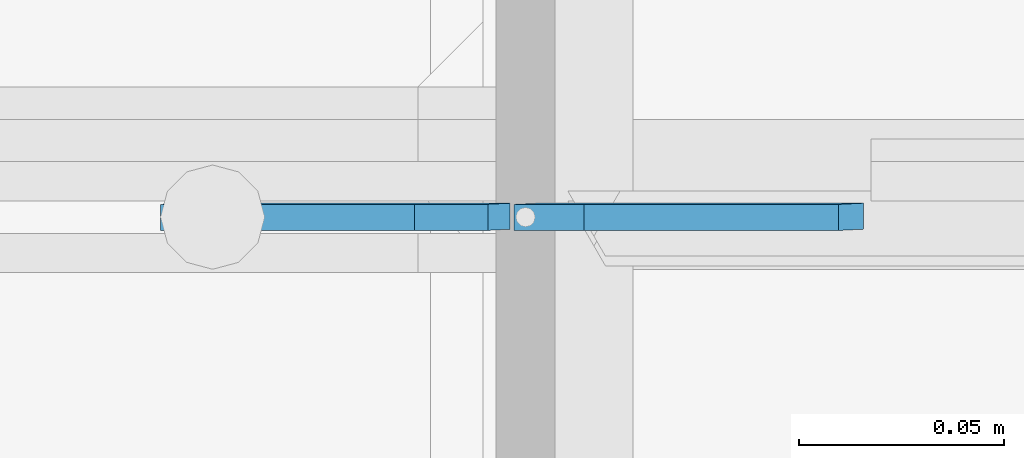
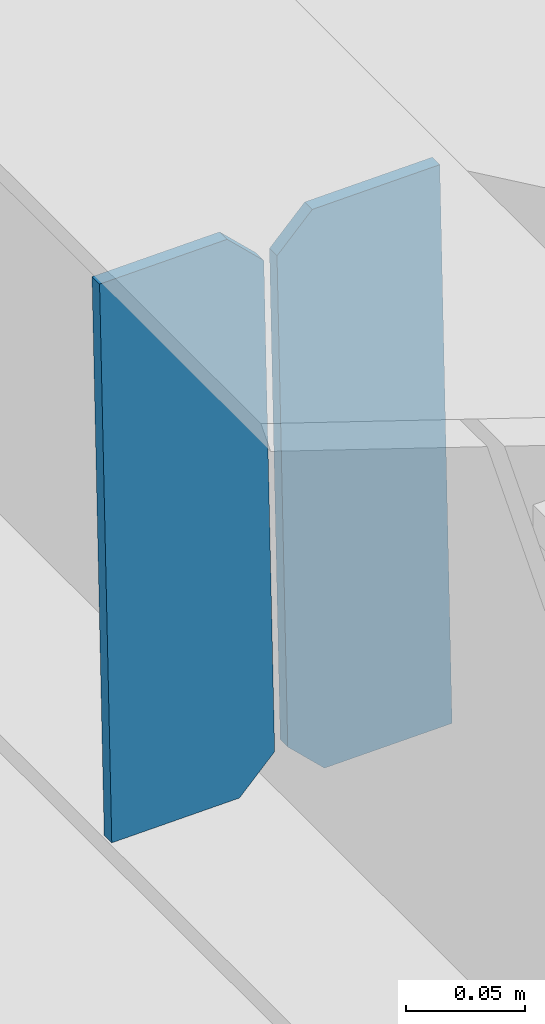
# One storey, part 3148 of 3843: 2 plates, 1 element without a shape of its own.
"""IFC2X3 building model written with IfcOpenShell, lengths in millimetres."""

from ifc_helpers import new_model, si_unit, frame, origin_with_axes, place, context, subcontext, project, spatial, faceted_brep, material, type_object, element, aggregate, save


model = new_model("IFC2X3")

# Units and contexts
model_context = context("Model", 3, precision=1e-05, world=origin_with_axes())
body_context = subcontext(model_context, "Body", "Model", "MODEL_VIEW")
ifc_project = project(units=[si_unit("LENGTHUNIT", "METRE", prefix="MILLI"), si_unit("AREAUNIT", "SQUARE_METRE"), si_unit("VOLUMEUNIT", "CUBIC_METRE"), si_unit("MASSUNIT", "GRAM", prefix="KILO"), si_unit("TIMEUNIT", "SECOND"), si_unit("PLANEANGLEUNIT", "RADIAN"), si_unit("SOLIDANGLEUNIT", "STERADIAN"), si_unit("THERMODYNAMICTEMPERATUREUNIT", "DEGREE_CELSIUS"), si_unit("LUMINOUSINTENSITYUNIT", "LUMEN")], contexts=[model_context])

# Site, building, storey
site_placement = place(None, origin_with_axes())
site = spatial("IfcSite", under=ifc_project, at=site_placement, CompositionType="ELEMENT")
building_placement = place(site_placement, origin_with_axes())
building = spatial("IfcBuilding", under=site, at=building_placement, Name="Undefined", CompositionType="ELEMENT")
storey_placement = place(building_placement, origin_with_axes())
storey = spatial("IfcBuildingStorey", under=building, at=storey_placement, Name="Undefined", CompositionType="ELEMENT", Elevation=0.0)

# Assembly, plates
assembly_placement = place(storey_placement, origin_with_axes())
assembly = element("IfcElementAssembly", 1, at=assembly_placement, inside=storey, Name="BEAM", AssemblyPlace="NOTDEFINED", PredefinedType="RIGID_FRAME")
ifc_material = material(Name="STEEL/A572-50")
plate_type = type_object("IfcPlateType", PredefinedType="NOTDEFINED")
plate_1_placement = place(assembly_placement, frame((56013.0964782664, 25616.1315277018, 45841.3616399231), z_axis=(-0.0211520978121262, -0.00105623500043294, 0.999775711410199), x_axis=(-0.999776269351372, 2.23470000204419e-05, -0.0211520860074212)))
plate_1 = element("IfcPlate", 2, at=plate_1_placement, type_object=plate_type, material=ifc_material, Name="STIFFENER", context=body_context, shape_type="Brep", body=[
    faceted_brep([(0.0, -3.17499999999927, 0.0), (6.83940015733242e-10, -3.17499999996653, 288.924999998613), (6.54836185276508e-10, 3.17500000001746, 288.924999998591), (0.0, 3.17499999999927, 0.0), (61.9125003828667, -3.17499999997744, 288.924999998599), (61.9125003828522, 3.17500000002838, 288.924999998584), (79.3750000013097, -3.17499999997744, 271.462500380039), (79.375000001266, 3.17500000002838, 271.462500380017), (79.375000000713, -3.17499999999927, 17.4624996185448), (79.3750000006694, 3.17500000000291, 17.462499618523), (61.9125003821828, -3.17499999999563, -1.45519152283669e-11), (61.9125003821682, 3.17500000000655, -2.91038304567337e-11)], [[[0, 1, 2, 3]], [[1, 4, 5, 2]], [[4, 6, 7, 5]], [[6, 8, 9, 7]], [[8, 10, 11, 9]], [[10, 0, 3, 11]], [[5, 7, 9, 11, 3, 2]], [[10, 8, 6, 4, 1, 0]]]),
])
plate_2_placement = place(assembly_placement, frame((55927.3906575768, 25616.1334433623, 45839.5483773328), z_axis=(-0.0211520978121262, -0.00105623500043294, 0.999775711410199), x_axis=(-0.999776269351372, 2.23470000204419e-05, -0.0211520860074212)))
plate_2 = element("IfcPlate", 3, at=plate_2_placement, type_object=plate_type, material=ifc_material, Name="STIFFENER", context=body_context, shape_type="Brep", body=[
    faceted_brep([(5.82076609134674e-11, -3.17499999999927, 17.4624996185667), (6.25732354819775e-10, -3.17499999997744, 271.462500380054), (5.82076609134674e-10, 3.17500000002474, 271.462500380039), (0.0, 3.17500000000655, 17.4624996185521), (17.462499619156, -3.17499999997744, 288.924999998606), (17.4624996191269, 3.17500000002474, 288.924999998591), (79.3750000013242, -3.17500000025029, 288.924999998591), (79.3750000013097, 3.1749999997337, 288.92499999857), (79.3750000006548, -3.17500000026484, -2.18278728425503e-11), (79.3750000006403, 3.17499999969732, -2.91038304567337e-11), (17.4624996184866, -3.17500000000291, 7.27595761418343e-12), (17.462499618443, 3.17500000000291, -7.27595761418343e-12)], [[[0, 1, 2, 3]], [[1, 4, 5, 2]], [[4, 6, 7, 5]], [[6, 8, 9, 7]], [[8, 10, 11, 9]], [[10, 0, 3, 11]], [[5, 7, 9, 11, 3, 2]], [[10, 8, 6, 4, 1, 0]]]),
])
aggregate(assembly, [plate_1, plate_2])

save(model, "model.ifc")
